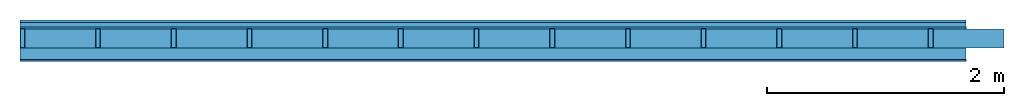
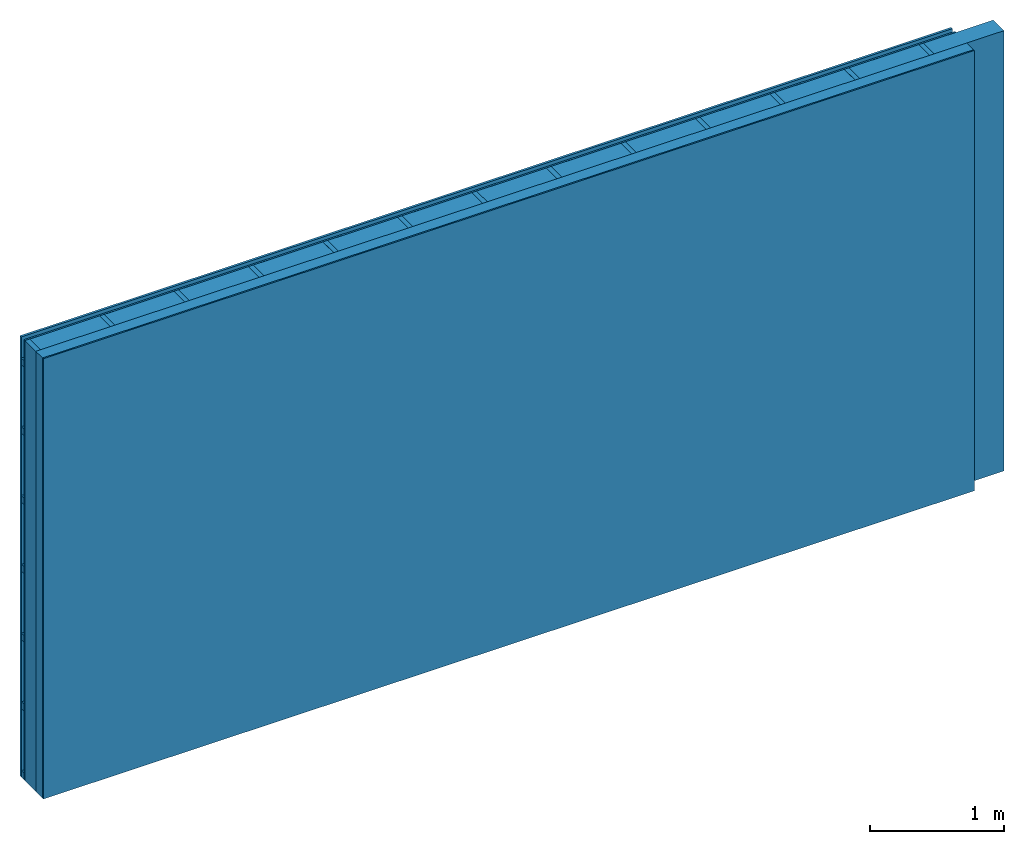
# One storey: 4 plates, 3 members, 1 element without a shape of its own.
"""IFC4 building model written with IfcOpenShell, lengths in metres."""

from ifc_helpers import new_model, si_unit, derived_unit, direction, frame, frame_2d, origin, origin_with_axes, place, context, project, spatial, rectangle, extrude, material, layer, layer_set, type_object, element, aggregate, save


model = new_model("IFC4")

# Units and contexts
plan_context = context("Plan", 3, precision=1e-05, world=origin(), true_north=direction((0.0, 1.0)))
model_context = context("Model", 3, precision=1e-05, world=origin(), true_north=direction((0.0, 1.0)))
ifc_project = project(units=[si_unit("LENGTHUNIT", "METRE"), derived_unit("SOUNDPRESSUREUNIT", [(si_unit("PRESSUREUNIT", "PASCAL", prefix="MICRO"), 0)]), si_unit("ENERGYUNIT", "JOULE", prefix="MEGA"), si_unit("MASSUNIT", "GRAM", prefix="KILO"), derived_unit("THERMALTRANSMITTANCEUNIT", [(si_unit("POWERUNIT", "WATT"), 1), (si_unit("AREAUNIT", "SQUARE_METRE"), -1), (si_unit("THERMODYNAMICTEMPERATUREUNIT", "KELVIN"), -1)]), derived_unit("AREADENSITYUNIT", [(si_unit("MASSUNIT", "GRAM", prefix="KILO"), 1), (si_unit("AREAUNIT", "SQUARE_METRE"), -1)]), derived_unit("USERDEFINED", [(si_unit("ENERGYUNIT", "JOULE", prefix="MEGA"), 1), (si_unit("AREAUNIT", "SQUARE_METRE"), -1)])], contexts=[plan_context, model_context])

# Site, building, storey
site = spatial("IfcSite", under=ifc_project)
building_placement = place(None, origin())
building = spatial("IfcBuilding", under=site, at=building_placement)
storey_placement = place(building_placement, origin())
storey = spatial("IfcBuildingStorey", under=building, at=storey_placement)

# Wall, members, plates
ifc_material_1 = material(Name="Wood cladding horizontal, closed")
ifc_layer_1 = layer(ifc_material_1, 0.02, Name="Cover 1st layer")
ifc_layer_2 = layer(None, 0.04, Name="Battens / profiles (ventilation)")
ifc_material_2 = material(Category="03.007")
ifc_layer_3 = layer(ifc_material_2, 0.015, Name="outside 1st layer")
ifc_material_3 = material(Name="of the art")
ifc_layer_4 = layer(ifc_material_3, 0.0, Name="Bond")
ifc_layer_5 = layer(None, 0.16, Name="Support")
ifc_layer_6 = layer(ifc_material_3, 0.0, Name="Bond")
ifc_material_4 = material(Name="Solid timber panel")
ifc_layer_7 = layer(ifc_material_4, 0.1, Name="1st layer")
ifc_material_5 = material(Name="Plasterboard type A", Category="03.008")
ifc_layer_8 = layer(ifc_material_5, 0.0125, Name="Covering 1st layer")
ifc_material_6 = material(Name="joints", Category="04.017")
ifc_layer_9 = layer(ifc_material_6, 0.0, Name="Surface")
ifc_layer_set = layer_set([ifc_layer_1, ifc_layer_2, ifc_layer_3, ifc_layer_4, ifc_layer_5, ifc_layer_6, ifc_layer_7, ifc_layer_8, ifc_layer_9])
wall_type = type_object("IfcWallType", Name="D0989", PredefinedType="NOTDEFINED", material=ifc_layer_set)
wall_placement = place(None, frame((0.0, 0.0, 0.0), z_axis=(0.0, -1.0, 0.0), x_axis=(1.0, 0.0, 0.0)))
wall = element("IfcWall", 1, at=wall_placement, inside=storey, type_object=wall_type, material=ifc_layer_set, Name="Wall #1")
ifc_material_7 = material()
member_1_placement = place(wall_placement, origin())
member_1 = element("IfcMember", 2, at=member_1_placement, material=ifc_material_7, Name="Battens / profiles (ventilation)", context=plan_context, shape_type="SweptSolid", body=[
    extrude(rectangle(XDim=0.06, YDim=0.04, at=frame_2d((0.03, 0.02), x_axis=(1.0, 0.0))), frame((0.0, 0.0, 0.02), z_axis=(1.0, 0.0, 0.0), x_axis=(0.0, 1.0, 0.0)), (0.0, 0.0, 1.0), 8.0),
    extrude(rectangle(XDim=0.06, YDim=0.04, at=frame_2d((0.03, 0.02), x_axis=(1.0, 0.0))), frame((0.0, 0.625, 0.02), z_axis=(1.0, 0.0, 0.0), x_axis=(0.0, 1.0, 0.0)), (0.0, 0.0, 1.0), 8.0),
    extrude(rectangle(XDim=0.06, YDim=0.04, at=frame_2d((0.03, 0.02), x_axis=(1.0, 0.0))), frame((0.0, 1.25, 0.02), z_axis=(1.0, 0.0, 0.0), x_axis=(0.0, 1.0, 0.0)), (0.0, 0.0, 1.0), 8.0),
    extrude(rectangle(XDim=0.06, YDim=0.04, at=frame_2d((0.03, 0.02), x_axis=(1.0, 0.0))), frame((0.0, 1.875, 0.02), z_axis=(1.0, 0.0, 0.0), x_axis=(0.0, 1.0, 0.0)), (0.0, 0.0, 1.0), 8.0),
    extrude(rectangle(XDim=0.06, YDim=0.04, at=frame_2d((0.03, 0.02), x_axis=(1.0, 0.0))), frame((0.0, 2.5, 0.02), z_axis=(1.0, 0.0, 0.0), x_axis=(0.0, 1.0, 0.0)), (0.0, 0.0, 1.0), 8.0),
    extrude(rectangle(XDim=0.06, YDim=0.04, at=frame_2d((0.03, 0.02), x_axis=(1.0, 0.0))), frame((0.0, 3.125, 0.02), z_axis=(1.0, 0.0, 0.0), x_axis=(0.0, 1.0, 0.0)), (0.0, 0.0, 1.0), 8.0),
    extrude(rectangle(XDim=0.06, YDim=0.04, at=frame_2d((0.03, 0.02), x_axis=(1.0, 0.0))), frame((0.0, 3.75, 0.02), z_axis=(1.0, 0.0, 0.0), x_axis=(0.0, 1.0, 0.0)), (0.0, 0.0, 1.0), 8.0),
])
ifc_material_8 = material()
member_2_placement = place(wall_placement, origin())
member_2 = element("IfcMember", 3, at=member_2_placement, material=ifc_material_8, Name="Support", context=plan_context, shape_type="SweptSolid", body=[
    extrude(rectangle(XDim=0.04, YDim=0.16, at=frame_2d((0.02, 0.08), x_axis=(1.0, 0.0))), frame((0.0, 4.0, 0.075), z_axis=(0.0, -1.0, 0.0), x_axis=(1.0, 0.0, 0.0)), (0.0, 0.0, 1.0), 4.0),
    extrude(rectangle(XDim=0.04, YDim=0.16, at=frame_2d((0.02, 0.08), x_axis=(1.0, 0.0))), frame((0.64, 4.0, 0.075), z_axis=(0.0, -1.0, 0.0), x_axis=(1.0, 0.0, 0.0)), (0.0, 0.0, 1.0), 4.0),
    extrude(rectangle(XDim=0.04, YDim=0.16, at=frame_2d((0.02, 0.08), x_axis=(1.0, 0.0))), frame((1.28, 4.0, 0.075), z_axis=(0.0, -1.0, 0.0), x_axis=(1.0, 0.0, 0.0)), (0.0, 0.0, 1.0), 4.0),
    extrude(rectangle(XDim=0.04, YDim=0.16, at=frame_2d((0.02, 0.08), x_axis=(1.0, 0.0))), frame((1.92, 4.0, 0.075), z_axis=(0.0, -1.0, 0.0), x_axis=(1.0, 0.0, 0.0)), (0.0, 0.0, 1.0), 4.0),
    extrude(rectangle(XDim=0.04, YDim=0.16, at=frame_2d((0.02, 0.08), x_axis=(1.0, 0.0))), frame((2.56, 4.0, 0.075), z_axis=(0.0, -1.0, 0.0), x_axis=(1.0, 0.0, 0.0)), (0.0, 0.0, 1.0), 4.0),
    extrude(rectangle(XDim=0.04, YDim=0.16, at=frame_2d((0.02, 0.08), x_axis=(1.0, 0.0))), frame((3.2, 4.0, 0.075), z_axis=(0.0, -1.0, 0.0), x_axis=(1.0, 0.0, 0.0)), (0.0, 0.0, 1.0), 4.0),
    extrude(rectangle(XDim=0.04, YDim=0.16, at=frame_2d((0.02, 0.08), x_axis=(1.0, 0.0))), frame((3.84, 4.0, 0.075), z_axis=(0.0, -1.0, 0.0), x_axis=(1.0, 0.0, 0.0)), (0.0, 0.0, 1.0), 4.0),
    extrude(rectangle(XDim=0.04, YDim=0.16, at=frame_2d((0.02, 0.08), x_axis=(1.0, 0.0))), frame((4.48, 4.0, 0.075), z_axis=(0.0, -1.0, 0.0), x_axis=(1.0, 0.0, 0.0)), (0.0, 0.0, 1.0), 4.0),
    extrude(rectangle(XDim=0.04, YDim=0.16, at=frame_2d((0.02, 0.08), x_axis=(1.0, 0.0))), frame((5.12, 4.0, 0.075), z_axis=(0.0, -1.0, 0.0), x_axis=(1.0, 0.0, 0.0)), (0.0, 0.0, 1.0), 4.0),
    extrude(rectangle(XDim=0.04, YDim=0.16, at=frame_2d((0.02, 0.08), x_axis=(1.0, 0.0))), frame((5.76, 4.0, 0.075), z_axis=(0.0, -1.0, 0.0), x_axis=(1.0, 0.0, 0.0)), (0.0, 0.0, 1.0), 4.0),
    extrude(rectangle(XDim=0.04, YDim=0.16, at=frame_2d((0.02, 0.08), x_axis=(1.0, 0.0))), frame((6.4, 4.0, 0.075), z_axis=(0.0, -1.0, 0.0), x_axis=(1.0, 0.0, 0.0)), (0.0, 0.0, 1.0), 4.0),
    extrude(rectangle(XDim=0.04, YDim=0.16, at=frame_2d((0.02, 0.08), x_axis=(1.0, 0.0))), frame((7.04, 4.0, 0.075), z_axis=(0.0, -1.0, 0.0), x_axis=(1.0, 0.0, 0.0)), (0.0, 0.0, 1.0), 4.0),
    extrude(rectangle(XDim=0.04, YDim=0.16, at=frame_2d((0.02, 0.08), x_axis=(1.0, 0.0))), frame((7.68, 4.0, 0.075), z_axis=(0.0, -1.0, 0.0), x_axis=(1.0, 0.0, 0.0)), (0.0, 0.0, 1.0), 4.0),
])
ifc_material_9 = material(Name="Mineral wool")
member_3_placement = place(wall_placement, origin())
member_3 = element("IfcMember", 4, at=member_3_placement, material=ifc_material_9, Name="Cavity", context=plan_context, shape_type="SweptSolid", body=[
    extrude(rectangle(XDim=0.6, YDim=0.16, at=frame_2d((0.3, 0.08), x_axis=(1.0, 0.0))), frame((0.04, 4.0, 0.075), z_axis=(0.0, -1.0, 0.0), x_axis=(1.0, 0.0, 0.0)), (0.0, 0.0, 1.0), 4.0),
    extrude(rectangle(XDim=0.6, YDim=0.16, at=frame_2d((0.3, 0.08), x_axis=(1.0, 0.0))), frame((0.68, 4.0, 0.075), z_axis=(0.0, -1.0, 0.0), x_axis=(1.0, 0.0, 0.0)), (0.0, 0.0, 1.0), 4.0),
    extrude(rectangle(XDim=0.6, YDim=0.16, at=frame_2d((0.3, 0.08), x_axis=(1.0, 0.0))), frame((1.32, 4.0, 0.075), z_axis=(0.0, -1.0, 0.0), x_axis=(1.0, 0.0, 0.0)), (0.0, 0.0, 1.0), 4.0),
    extrude(rectangle(XDim=0.6, YDim=0.16, at=frame_2d((0.3, 0.08), x_axis=(1.0, 0.0))), frame((1.96, 4.0, 0.075), z_axis=(0.0, -1.0, 0.0), x_axis=(1.0, 0.0, 0.0)), (0.0, 0.0, 1.0), 4.0),
    extrude(rectangle(XDim=0.6, YDim=0.16, at=frame_2d((0.3, 0.08), x_axis=(1.0, 0.0))), frame((2.6, 4.0, 0.075), z_axis=(0.0, -1.0, 0.0), x_axis=(1.0, 0.0, 0.0)), (0.0, 0.0, 1.0), 4.0),
    extrude(rectangle(XDim=0.6, YDim=0.16, at=frame_2d((0.3, 0.08), x_axis=(1.0, 0.0))), frame((3.24, 4.0, 0.075), z_axis=(0.0, -1.0, 0.0), x_axis=(1.0, 0.0, 0.0)), (0.0, 0.0, 1.0), 4.0),
    extrude(rectangle(XDim=0.6, YDim=0.16, at=frame_2d((0.3, 0.08), x_axis=(1.0, 0.0))), frame((3.88, 4.0, 0.075), z_axis=(0.0, -1.0, 0.0), x_axis=(1.0, 0.0, 0.0)), (0.0, 0.0, 1.0), 4.0),
    extrude(rectangle(XDim=0.6, YDim=0.16, at=frame_2d((0.3, 0.08), x_axis=(1.0, 0.0))), frame((4.52, 4.0, 0.075), z_axis=(0.0, -1.0, 0.0), x_axis=(1.0, 0.0, 0.0)), (0.0, 0.0, 1.0), 4.0),
    extrude(rectangle(XDim=0.6, YDim=0.16, at=frame_2d((0.3, 0.08), x_axis=(1.0, 0.0))), frame((5.16, 4.0, 0.075), z_axis=(0.0, -1.0, 0.0), x_axis=(1.0, 0.0, 0.0)), (0.0, 0.0, 1.0), 4.0),
    extrude(rectangle(XDim=0.6, YDim=0.16, at=frame_2d((0.3, 0.08), x_axis=(1.0, 0.0))), frame((5.8, 4.0, 0.075), z_axis=(0.0, -1.0, 0.0), x_axis=(1.0, 0.0, 0.0)), (0.0, 0.0, 1.0), 4.0),
    extrude(rectangle(XDim=0.6, YDim=0.16, at=frame_2d((0.3, 0.08), x_axis=(1.0, 0.0))), frame((6.44, 4.0, 0.075), z_axis=(0.0, -1.0, 0.0), x_axis=(1.0, 0.0, 0.0)), (0.0, 0.0, 1.0), 4.0),
    extrude(rectangle(XDim=0.6, YDim=0.16, at=frame_2d((0.3, 0.08), x_axis=(1.0, 0.0))), frame((7.08, 4.0, 0.075), z_axis=(0.0, -1.0, 0.0), x_axis=(1.0, 0.0, 0.0)), (0.0, 0.0, 1.0), 4.0),
    extrude(rectangle(XDim=0.6, YDim=0.16, at=frame_2d((0.3, 0.08), x_axis=(1.0, 0.0))), frame((7.72, 4.0, 0.075), z_axis=(0.0, -1.0, 0.0), x_axis=(1.0, 0.0, 0.0)), (0.0, 0.0, 1.0), 4.0),
])
plate_1_placement = place(wall_placement, origin())
plate_1 = element("IfcPlate", 5, at=plate_1_placement, material=ifc_material_1, Name="Cover 1st layer", context=plan_context, shape_type="SweptSolid", body=[
    extrude(rectangle(XDim=8.0, YDim=4.0, at=frame_2d((4.0, 2.0), x_axis=(1.0, 0.0))), origin_with_axes(), (0.0, 0.0, 1.0), 0.02),
])
plate_2_placement = place(wall_placement, origin())
plate_2 = element("IfcPlate", 6, at=plate_2_placement, material=ifc_material_2, Name="outside 1st layer", context=plan_context, shape_type="SweptSolid", body=[
    extrude(rectangle(XDim=8.0, YDim=4.0, at=frame_2d((4.0, 2.0), x_axis=(1.0, 0.0))), frame((0.0, 0.0, 0.06), z_axis=(0.0, 0.0, 1.0), x_axis=(1.0, 0.0, 0.0)), (0.0, 0.0, 1.0), 0.015),
])
plate_3_placement = place(wall_placement, origin())
plate_3 = element("IfcPlate", 7, at=plate_3_placement, material=ifc_material_4, Name="1st layer", context=plan_context, shape_type="SweptSolid", body=[
    extrude(rectangle(XDim=8.0, YDim=4.0, at=frame_2d((4.0, 2.0), x_axis=(1.0, 0.0))), frame((0.0, 0.0, 0.235), z_axis=(0.0, 0.0, 1.0), x_axis=(1.0, 0.0, 0.0)), (0.0, 0.0, 1.0), 0.1),
])
plate_4_placement = place(wall_placement, origin())
plate_4 = element("IfcPlate", 8, at=plate_4_placement, material=ifc_material_5, Name="Covering 1st layer", context=plan_context, shape_type="SweptSolid", body=[
    extrude(rectangle(XDim=8.0, YDim=4.0, at=frame_2d((4.0, 2.0), x_axis=(1.0, 0.0))), frame((0.0, 0.0, 0.335), z_axis=(0.0, 0.0, 1.0), x_axis=(1.0, 0.0, 0.0)), (0.0, 0.0, 1.0), 0.0125),
])
aggregate(wall, [plate_1, member_1, plate_2, member_2, member_3, plate_3, plate_4])

save(model, "model.ifc")
